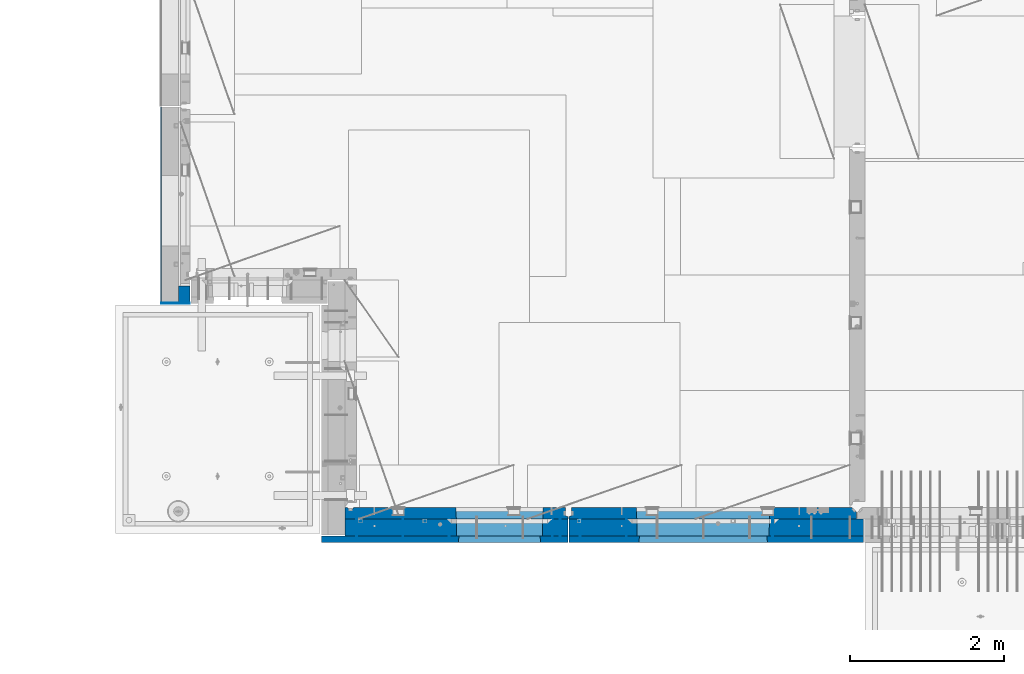
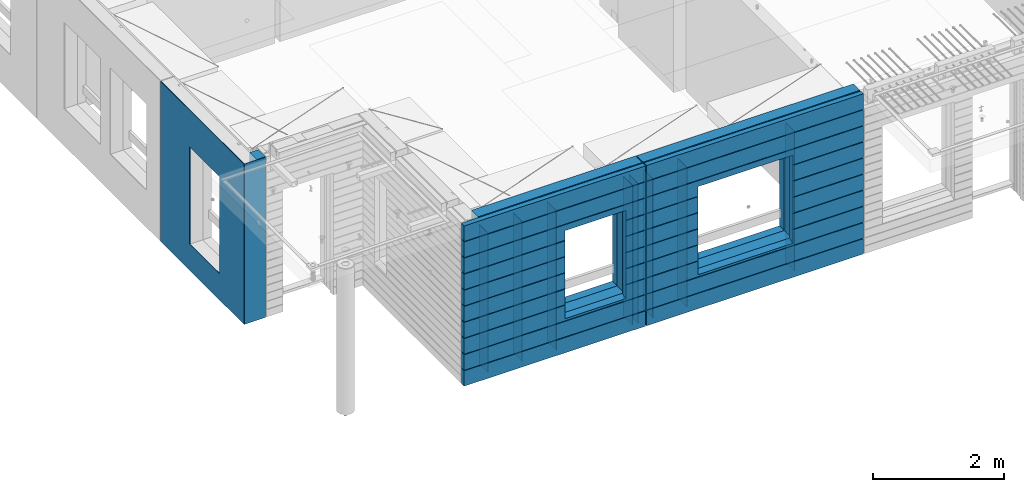
# One storey, part 226 of 349: 17 walls, 3 elements without a shape of their own.
"""IFC2X3 building model written with IfcOpenShell, lengths in millimetres."""

from ifc_helpers import new_model, si_unit, frame, origin_with_axes, place, context, subcontext, project, spatial, faceted_brep, material, type_object, element, aggregate, save


model = new_model("IFC2X3")

# Units and contexts
model_context = context("Model", 3, precision=1e-05, world=origin_with_axes())
body_context = subcontext(model_context, "Body", "Model", "MODEL_VIEW")
ifc_project = project(units=[si_unit("LENGTHUNIT", "METRE", prefix="MILLI"), si_unit("AREAUNIT", "SQUARE_METRE"), si_unit("VOLUMEUNIT", "CUBIC_METRE"), si_unit("MASSUNIT", "GRAM", prefix="KILO"), si_unit("TIMEUNIT", "SECOND"), si_unit("PLANEANGLEUNIT", "RADIAN"), si_unit("SOLIDANGLEUNIT", "STERADIAN"), si_unit("THERMODYNAMICTEMPERATUREUNIT", "DEGREE_CELSIUS"), si_unit("LUMINOUSINTENSITYUNIT", "LUMEN")], contexts=[model_context])

# Site, building, storey
site_placement = place(None, origin_with_axes())
site = spatial("IfcSite", under=ifc_project, at=site_placement, CompositionType="ELEMENT")
building_placement = place(site_placement, origin_with_axes())
building = spatial("IfcBuilding", under=site, at=building_placement, CompositionType="ELEMENT")
storey_placement = place(building_placement, origin_with_axes())
storey = spatial("IfcBuildingStorey", under=building, at=storey_placement, Name="4", CompositionType="ELEMENT", Elevation=0.0)

# Assembly, walls
assembly_1_placement = place(storey_placement, origin_with_axes())
assembly_1 = element("IfcElementAssembly", 1, at=assembly_1_placement, inside=storey, AssemblyPlace="NOTDEFINED", PredefinedType="REINFORCEMENT_UNIT")
ifc_material_1 = material(Name="Undefined")
wall_type_1 = type_object("IfcWallType", PredefinedType="NOTDEFINED")
wall_1_placement = place(assembly_1_placement, frame((10165.0, 7880.0, 92115.0), z_axis=(0.0, 0.0, 1.0), x_axis=(0.0, -1.0, 0.0)))
wall_1 = element("IfcWall", 2, at=wall_1_placement, type_object=wall_type_1, material=ifc_material_1, Name="(PD)", context=body_context, shape_type="Brep", body=[
    faceted_brep([(0.0, 5.0, -1300.0), (0.0, 5.0, 1300.0), (280.0, 5.0, 1300.0), (280.0, 5.0, -1300.0), (0.0, -5.0, 1300.0), (280.0, -5.0, 1300.0), (0.0, -5.0, -1300.0), (280.0, -5.0, -1300.0)], [[[0, 1, 2, 3]], [[1, 4, 5, 2]], [[4, 6, 7, 5]], [[6, 0, 3, 7]], [[5, 7, 3, 2]], [[6, 4, 1, 0]]]),
])
wall_2_placement = place(assembly_1_placement, frame((10765.0, 7880.0, 92115.0), z_axis=(0.0, 0.0, 1.0), x_axis=(0.0, -1.0, 0.0)))
wall_2 = element("IfcWall", 3, at=wall_2_placement, type_object=wall_type_1, material=ifc_material_1, Name="(PD)", context=body_context, shape_type="Brep", body=[
    faceted_brep([(0.0, 5.0, -1300.0), (0.0, 5.0, 1300.0), (280.0, 5.0, 1300.0), (280.0, 5.0, -1300.0), (0.0, -5.0, 1300.0), (280.0, -5.0, 1300.0), (0.0, -5.0, -1300.0), (280.0, -5.0, -1300.0)], [[[0, 1, 2, 3]], [[1, 4, 5, 2]], [[4, 6, 7, 5]], [[6, 0, 3, 7]], [[5, 7, 3, 2]], [[6, 4, 1, 0]]]),
])
wall_3_placement = place(assembly_1_placement, frame((12705.0, 7880.0, 92115.0), z_axis=(0.0, 0.0, 1.0), x_axis=(0.0, -1.0, 0.0)))
wall_3 = element("IfcWall", 4, at=wall_3_placement, type_object=wall_type_1, material=ifc_material_1, Name="(PD)", context=body_context, shape_type="Brep", body=[
    faceted_brep([(0.0, 5.0, -1300.0), (0.0, 5.0, 1300.0), (280.0, 5.0, 1300.0), (280.0, 5.0, -1300.0), (0.0, -5.0, 1300.0), (280.0, -5.0, 1300.0), (0.0, -5.0, -1300.0), (280.0, -5.0, -1300.0)], [[[0, 1, 2, 3]], [[1, 4, 5, 2]], [[4, 6, 7, 5]], [[6, 0, 3, 7]], [[5, 7, 3, 2]], [[6, 4, 1, 0]]]),
])
wall_4_placement = place(assembly_1_placement, frame((12805.0, 7880.0, 92115.0), z_axis=(0.0, 0.0, 1.0), x_axis=(0.0, -1.0, 0.0)))
wall_4 = element("IfcWall", 5, at=wall_4_placement, type_object=wall_type_1, material=ifc_material_1, Name="(PD)", context=body_context, shape_type="Brep", body=[
    faceted_brep([(0.0, 5.0, -1300.0), (0.0, 5.0, 1300.0), (280.0, 5.0, 1300.0), (280.0, 5.0, -1300.0), (0.0, -5.0, 1300.0), (280.0, -5.0, 1300.0), (0.0, -5.0, -1300.0), (280.0, -5.0, -1300.0)], [[[0, 1, 2, 3]], [[1, 4, 5, 2]], [[4, 6, 7, 5]], [[6, 0, 3, 7]], [[5, 7, 3, 2]], [[6, 4, 1, 0]]]),
])
wall_5_placement = place(assembly_1_placement, frame((11365.0, 7880.0, 92115.0), z_axis=(0.0, 0.0, 1.0), x_axis=(0.0, -1.0, 0.0)))
wall_5 = element("IfcWall", 6, at=wall_5_placement, type_object=wall_type_1, material=ifc_material_1, Name="(PD)", context=body_context, shape_type="Brep", body=[
    faceted_brep([(0.0, 5.0, -1300.0), (0.0, 5.0, 1300.0), (280.0, 5.0, 1300.0), (280.0, 5.0, -1300.0), (0.0, -5.0, 1300.0), (280.0, -5.0, 1300.0), (0.0, -5.0, -1300.0), (280.0, -5.0, -1300.0)], [[[0, 1, 2, 3]], [[1, 4, 5, 2]], [[4, 6, 7, 5]], [[6, 0, 3, 7]], [[5, 7, 3, 2]], [[6, 4, 1, 0]]]),
])

assembly_2_placement = place(storey_placement, origin_with_axes())
assembly_2 = element("IfcElementAssembly", 7, at=assembly_2_placement, inside=storey, AssemblyPlace="NOTDEFINED", PredefinedType="REINFORCEMENT_UNIT")
wall_6_placement = place(assembly_2_placement, frame((13665.0, 7880.0, 92115.0), z_axis=(0.0, 0.0, 1.0), x_axis=(0.0, -1.0, 0.0)))
wall_6 = element("IfcWall", 8, at=wall_6_placement, type_object=wall_type_1, material=ifc_material_1, Name="(PD)", context=body_context, shape_type="Brep", body=[
    faceted_brep([(0.0, 5.0, -1300.0), (0.0, 5.0, 1300.0), (280.0, 5.0, 1300.0), (280.0, 5.0, -1300.0), (0.0, -5.0, 1300.0), (280.0, -5.0, 1300.0), (0.0, -5.0, -1300.0), (280.0, -5.0, -1300.0)], [[[0, 1, 2, 3]], [[1, 4, 5, 2]], [[4, 6, 7, 5]], [[6, 0, 3, 7]], [[5, 7, 3, 2]], [[6, 4, 1, 0]]]),
])
wall_7_placement = place(assembly_2_placement, frame((13065.0, 7880.0, 92115.0), z_axis=(0.0, 0.0, 1.0), x_axis=(0.0, -1.0, 0.0)))
wall_7 = element("IfcWall", 9, at=wall_7_placement, type_object=wall_type_1, material=ifc_material_1, Name="(PD)", context=body_context, shape_type="Brep", body=[
    faceted_brep([(0.0, 5.0, -1300.0), (0.0, 5.0, 1300.0), (280.0, 5.0, 1300.0), (280.0, 5.0, -1300.0), (0.0, -5.0, 1300.0), (280.0, -5.0, 1300.0), (0.0, -5.0, -1300.0), (280.0, -5.0, -1300.0)], [[[0, 1, 2, 3]], [[1, 4, 5, 2]], [[4, 6, 7, 5]], [[6, 0, 3, 7]], [[5, 7, 3, 2]], [[6, 4, 1, 0]]]),
])
wall_8_placement = place(assembly_2_placement, frame((15565.0, 7880.0, 92115.0), z_axis=(0.0, 0.0, 1.0), x_axis=(0.0, -1.0, 0.0)))
wall_8 = element("IfcWall", 10, at=wall_8_placement, type_object=wall_type_1, material=ifc_material_1, Name="(PD)", context=body_context, shape_type="Brep", body=[
    faceted_brep([(0.0, 5.0, -1300.0), (0.0, 5.0, 1300.0), (280.0, 5.0, 1300.0), (280.0, 5.0, -1300.0), (0.0, -5.0, 1300.0), (280.0, -5.0, 1300.0), (0.0, -5.0, -1300.0), (280.0, -5.0, -1300.0)], [[[0, 1, 2, 3]], [[1, 4, 5, 2]], [[4, 6, 7, 5]], [[6, 0, 3, 7]], [[5, 7, 3, 2]], [[6, 4, 1, 0]]]),
])

# Assembly, wall
assembly_3_placement = place(storey_placement, origin_with_axes())
assembly_3 = element("IfcElementAssembly", 11, at=assembly_3_placement, inside=storey, AssemblyPlace="NOTDEFINED", PredefinedType="REINFORCEMENT_UNIT")
ifc_material_2 = material()
wall_type_2 = type_object("IfcWallType", PredefinedType="NOTDEFINED")
wall_9_placement = place(assembly_3_placement, frame((8000.00051558999, 10765.0000158944, 92247.5), z_axis=(0.0, 0.0, 1.0), x_axis=(-0.999999999997437, -2.26400000064461e-06, 0.0)))
wall_9 = element("IfcWall", 12, at=wall_9_placement, type_object=wall_type_2, material=ifc_material_2, context=body_context, shape_type="Brep", body=[
    faceted_brep([(0.0, 110.0, -1492.5), (0.0, 110.0, 1492.5), (150.000694320282, 109.999999999998, 1492.5), (150.000694320282, 109.999999999998, -1492.5), (0.0, -110.0, 1492.5), (150.000694320282, -110.000000000004, 1492.5), (0.0, -110.0, -1492.5), (150.000694320282, -110.000000000004, -1492.5)], [[[0, 1, 2, 3]], [[1, 4, 5, 2]], [[4, 6, 7, 5]], [[6, 0, 3, 7]], [[5, 7, 3, 2]], [[6, 4, 1, 0]]]),
])

# Wall
ifc_material_3 = material(Name="COS5gt")
wall_10_placement = place(assembly_1_placement, frame((12912.5, 7740.0, 92247.5), z_axis=(0.0, 0.0, 1.0), x_axis=(-1.0, 3.00000001838171e-08, 0.0)))
wall_10 = element("IfcWall", 13, at=wall_10_placement, type_object=wall_type_2, material=ifc_material_3, context=body_context, shape_type="Brep", body=[
    faceted_brep([(7.5, 90.0, 1442.5), (2897.5, 90.0, 1442.5), (2897.5, 110.0, 1442.5), (7.5, 110.0, 1442.5), (7.5, 90.0, 1492.5), (2897.5, 90.0, 1492.5), (7.5, -110.0, 1492.5), (2897.5, -110.0, 1492.5), (2897.5, -110.0, -1492.5), (2897.5, 90.0, -1492.5), (2897.5, 90.0, -1442.5), (2897.5, 110.0, -1442.5), (7.5, 110.0, -1442.5), (7.5, 90.0, -1442.5), (339.499571152144, 110.0, -807.5), (369.499571152144, 110.0, -807.5), (1419.49957115214, 110.0, -807.5), (1449.49957115214, 110.0, -807.5), (1449.49957115214, 110.0, -802.5), (1449.49957115214, 110.0, 807.5), (339.499571152144, 110.0, 807.5), (339.499571152144, 110.0, -802.5), (333.553625206197, -110.0, -813.445945945947), (333.553625206197, -110.0, 813.445945945947), (1455.44551709809, -110.0, -813.445945945947), (1455.44551709809, -110.0, 813.445945945947), (7.5, -110.0, -1492.5), (7.5, 90.0, -1492.5)], [[[0, 1, 2, 3]], [[4, 5, 1, 0]], [[6, 7, 5, 4]], [[2, 1, 5, 7, 8, 9, 10, 11]], [[12, 11, 10, 13]], [[3, 2, 11, 12], [14, 15, 16, 17, 18, 19, 20, 21]], [[22, 14, 21, 20, 23]], [[24, 17, 16, 15, 14, 22]], [[18, 17, 24, 25, 19]], [[23, 20, 19, 25]], [[6, 26, 8, 7], [24, 22, 23, 25]], [[8, 26, 27, 9]], [[13, 10, 9, 27]], [[26, 6, 4, 0, 3, 12, 13, 27]]]),
])

wall_11_placement = place(assembly_2_placement, frame((16740.0, 7740.0, 92247.5), z_axis=(0.0, 0.0, 1.0), x_axis=(-1.0, 3.00000001838171e-08, 0.0)))
wall_11 = element("IfcWall", 14, at=wall_11_placement, type_object=wall_type_2, material=ifc_material_3, context=body_context, shape_type="Brep", body=[
    faceted_brep([(0.0, 90.0, 1442.5), (3820.0, 90.0, 1442.5), (3820.0, 110.0, 1442.5), (0.0, 110.0, 1442.5), (0.0, 90.0, 1492.5), (3820.0, 90.0, 1492.5), (0.0, -110.0, 1492.5), (3820.0, -110.0, 1492.5), (3820.0, -110.0, -1492.5), (3820.0, 90.0, -1492.5), (3820.0, 90.0, -1442.5), (3820.0, 110.0, -1442.5), (0.0, 110.0, -1442.5), (0.0, 90.0, -1442.5), (1224.99975425761, 110.0, -807.5), (1254.99975425761, 110.0, -807.5), (2904.99975425761, 110.0, -807.5), (2934.99975425761, 110.0, -807.5), (2934.99975425761, 110.0, -802.5), (2934.99975425761, 110.0, 807.5), (1224.99975425761, 110.0, 807.5), (1224.99975425761, 110.0, -802.5), (1219.05380831167, -110.0, -813.445945945947), (1219.05380831167, -110.0, 813.445945945947), (2940.94570020356, -110.0, -813.445945945947), (2940.94570020356, -110.0, 813.445945945947), (0.0, -110.0, -1492.5), (0.0, 90.0, -1492.5)], [[[0, 1, 2, 3]], [[4, 5, 1, 0]], [[6, 7, 5, 4]], [[2, 1, 5, 7, 8, 9, 10, 11]], [[12, 11, 10, 13]], [[3, 2, 11, 12], [14, 15, 16, 17, 18, 19, 20, 21]], [[22, 14, 21, 20, 23]], [[24, 17, 16, 15, 14, 22]], [[18, 17, 24, 25, 19]], [[23, 20, 19, 25]], [[6, 26, 8, 7], [24, 22, 23, 25]], [[8, 26, 27, 9]], [[13, 10, 9, 27]], [[27, 26, 6, 4, 0, 3, 12, 13]]]),
])

ifc_material_4 = material(Name="CONCRETE/C30/37")
wall_type_3 = type_object("IfcWallType", PredefinedType="NOTDEFINED")
wall_12_placement = place(assembly_1_placement, frame((12912.5, 7587.5, 92247.5), z_axis=(0.0, 0.0, 1.0), x_axis=(-1.0, 3.00000001838171e-08, 0.0)))
wall_12 = element("IfcWall", 15, at=wall_12_placement, type_object=wall_type_3, material=ifc_material_4, context=body_context, shape_type="Brep", body=[
    faceted_brep([(3207.5, -42.5, 1193.0000011433), (3207.5, 42.5, 1192.99999994476), (3197.49999925687, 32.4999992501671, 1194.99999999921), (3197.49999396174, -42.5, 1195.00000105656), (3197.49999368253, -42.5, 1205.00000145777), (3197.49999897767, 32.4999991121604, 1205.00000040043), (3207.5, 42.5, 1206.99999988925), (3207.5, -42.5, 1207.0000010878), (7.4999999999709, -42.5, -1492.5), (7.4999999999709, 42.5, -1492.5), (3207.5, 42.5, -1492.5), (3207.5, -42.5, -1492.5), (7.4999999999709, 42.5, -1207.00000005524), (3207.5, 42.5, -1207.00000005524), (3207.5, -42.5, -1206.9999988567), (3197.49999925687, 32.4999992501671, -1205.00000000079), (3197.49999396174, -42.5, -1204.99999894344), (7.4999999999709, 32.4999992501671, -1205.00000000079), (7.4999999999709, 32.4999991121604, -1194.99999959957), (3197.49999897767, 32.4999991121604, -1194.99999959957), (3197.49999368253, -42.5, -1194.99999854223), (3207.5, -42.5, -1192.9999989122), (3207.5, 42.5, -1193.00000011075), (3207.5, 42.5, -907.000000055239), (3207.5, -42.5, -906.9999988567), (7.4999999999709, 42.5, -1193.00000011075), (7.4999999999709, 42.5, -907.000000055239), (7.4999999999709, 32.4999992501671, -905.000000000786), (3197.49999925687, 32.4999992501671, -905.000000000786), (3197.49999396174, -42.5, -904.999998943444), (3197.49999897767, 32.4999991121604, -894.999999599575), (3197.49999368253, -42.5, -894.999998542233), (7.4999999999709, 32.4999991121604, -894.999999599575), (7.4999999999709, 42.5, -893.000000110755), (3207.5, 42.5, -893.000000110755), (3207.5, -42.5, -892.999998912201), (3207.5, 42.5, -607.000000055239), (3207.5, -42.5, -606.9999988567), (3197.49999925687, 32.4999992501671, -605.000000000786), (3197.49999396174, -42.5, -604.999998943444), (1429.49957115214, 42.5, -607.000000055239), (1428.32310047569, 32.4999992501653, -605.000000000786), (1428.32310045946, 32.4999991121585, -594.999999599575), (3197.49999897767, 32.4999991121604, -594.999999599575), (3197.49999368253, -42.5, -594.999998542233), (3207.5, 42.5, -593.000000110755), (3207.5, -42.5, -592.999998912201), (1429.49957115214, 42.5, -593.000000110755), (3207.5, 42.5, -307.000000055239), (1429.49957115214, 42.5, -307.000000055239), (3207.5, -42.5, -306.9999988567), (3197.49999925687, 32.4999992501671, -305.000000000786), (3197.49999396174, -42.5, -304.999998943444), (1428.32310047569, 32.4999992501653, -305.000000000786), (1428.32310045946, 32.4999991121585, -294.999999599575), (3197.49999897767, 32.4999991121604, -294.999999599575), (3197.49999368253, -42.5, -294.999998542233), (3207.5, 42.5, -293.000000110755), (3207.5, -42.5, -292.999998912201), (1429.49957115214, 42.5, -293.000000110755), (3207.5, 42.5, -7.00000005523907), (1429.49957115214, 42.5, -7.00000005523907), (3207.5, -42.5, -6.99999885669968), (3197.49999925687, 32.4999992501671, -5.0000000007858), (3197.49999396174, -42.5, -4.99999894344364), (1428.32310047569, 32.4999992501653, -5.0000000007858), (1428.32310045946, 32.4999991121585, 5.00000040042505), (3197.49999897767, 32.4999991121604, 5.00000040042505), (3197.49999368253, -42.5, 5.00000145776721), (3207.5, 42.5, 6.99999988924537), (3207.5, -42.5, 7.00000108779932), (1429.49957115214, 42.5, 6.99999988924537), (3207.5, 42.5, 292.999999944761), (1429.49957115214, 42.5, 292.999999944761), (3207.5, -42.5, 293.0000011433), (3197.49999925687, 32.4999992501671, 294.999999999214), (3197.49999396174, -42.5, 295.000001056556), (1428.32310047569, 32.4999992501653, 294.999999999214), (1428.32310045946, 32.4999991121585, 305.000000400425), (3197.49999897767, 32.4999991121604, 305.000000400425), (3197.49999368253, -42.5, 305.000001457767), (3207.5, -42.5, 307.000001087799), (3207.5, 42.5, 306.999999889245), (3207.5, 42.5, 592.999999944761), (3207.5, -42.5, 593.0000011433), (1429.49957115214, 42.5, 306.999999889245), (1429.49957115214, 42.5, 592.999999944761), (1428.32310047569, 32.4999992501653, 594.999999999214), (3197.49999925687, 32.4999992501671, 594.999999999214), (3197.49999396174, -42.5, 595.000001056556), (3197.49999897767, 32.4999991121604, 605.000000400425), (3197.49999368253, -42.5, 605.000001457767), (1428.32310045946, 32.4999991121585, 605.000000400425), (1429.49957115214, 42.5, 606.999999889245), (3207.5, 42.5, 606.999999889245), (3207.5, -42.5, 607.000001087799), (3207.5, 42.5, 892.999999944761), (3207.5, -42.5, 893.0000011433), (3197.49999925687, 32.4999992501671, 894.999999999214), (3197.49999396174, -42.5, 895.000001056556), (7.4999999999709, 42.5, 892.999999944761), (7.49999999998181, 32.4999992501671, 894.999999999214), (7.49999999998181, 32.4999991121604, 905.000000400425), (3197.49999897767, 32.4999991121604, 905.000000400425), (3197.49999368253, -42.5, 905.000001457767), (3207.5, -42.5, 907.000001087799), (3207.5, 42.5, 906.999999889245), (7.4999999999709, 42.5, 906.999999889245), (7.4999999999709, 42.5, 1192.99999994476), (7.49999999998363, 32.4999992501671, 1194.99999999921), (7.4999999999709, 42.5, 1492.5), (7.4999999999709, -42.5, 1492.5), (3207.5, -42.5, 1492.5), (3207.5, 42.5, 1492.5), (7.4999999999709, 42.5, 1206.99999988925), (7.49999999998363, 32.4999991121604, 1205.00000040043), (7.4999999999709, 42.5, 606.999999889245), (7.49999999997999, 32.4999991121604, 605.000000400425), (7.49999999997999, 32.4999992501671, 594.999999999214), (7.4999999999709, 42.5, 592.999999944761), (7.4999999999709, 42.5, 306.999999889245), (7.49999999997453, 32.4999991121604, 305.000000400425), (7.49999999997453, 32.4999992501671, 294.999999999214), (7.4999999999709, 42.5, 292.999999944761), (7.4999999999709, 42.5, 6.99999988924537), (7.4999999999709, 32.4999991121604, 5.00000040042505), (7.4999999999709, 32.4999992501671, -5.0000000007858), (7.4999999999709, 42.5, -7.00000005523907), (7.4999999999709, 42.5, -293.000000110755), (7.4999999999709, 32.4999991121604, -294.999999599575), (7.4999999999709, 32.4999992501671, -305.000000000786), (7.4999999999709, 42.5, -307.000000055239), (7.4999999999709, 42.5, -593.000000110755), (7.49999999996908, 32.4999991121604, -594.999999599575), (7.49999999996908, 32.4999992501671, -605.000000000786), (7.4999999999709, 42.5, -607.000000055239), (360.676041844832, 32.4999991121585, 605.000000400425), (360.676041828596, 32.4999992501653, 594.999999999214), (359.499571152144, 42.5, 592.999999944761), (359.499571152144, 42.5, 306.999999889245), (360.676041844832, 32.4999991121585, 305.000000400425), (360.676041828596, 32.4999992501653, 294.999999999214), (359.499571152144, 42.5, 292.999999944761), (359.499571152144, 42.5, 6.99999988924537), (360.676041844832, 32.4999991121585, 5.00000040042505), (360.676041828596, 32.4999992501653, -5.0000000007858), (359.499571152144, 42.5, -7.00000005523907), (359.499571152144, 42.5, -293.000000110755), (360.676041844832, 32.4999991121585, -294.999999599575), (360.676041828596, 32.4999992501653, -305.000000000786), (359.499571152144, 42.5, -307.000000055239), (359.499571152144, 42.5, -593.000000110755), (360.676041844832, 32.4999991121585, -594.999999599575), (360.676041828596, 32.4999992501653, -605.000000000786), (359.499571152144, 42.5, -607.000000055239), (1429.49957115214, 42.5, -857.5), (359.499571152144, 42.5, -857.5), (369.499571152144, -42.5, -807.5), (1419.49957115214, -42.5, -807.5), (1419.49957115214, -42.5, 782.5), (1419.49957115214, -42.5, 787.5), (1429.49957115214, 42.5, 782.5), (1419.49957115214, 42.5, 782.5), (369.499571152144, 42.5, 782.5), (359.499571152144, 42.5, 782.5), (359.499571152144, 42.5, 606.999999889245), (369.499571152144, -42.5, 787.5), (369.499571152144, -42.5, 782.5)], [[[0, 1, 2, 3]], [[4, 5, 6, 7]], [[3, 2, 5, 4]], [[8, 9, 10, 11]], [[10, 9, 12, 13]], [[11, 10, 13, 14]], [[14, 13, 15, 16]], [[12, 17, 15, 13]], [[17, 18, 19, 15]], [[16, 15, 19, 20]], [[21, 22, 23, 24]], [[20, 19, 22, 21]], [[18, 25, 22, 19]], [[22, 25, 26, 23]], [[26, 27, 28, 23]], [[24, 23, 28, 29]], [[29, 28, 30, 31]], [[27, 32, 30, 28]], [[32, 33, 34, 30]], [[31, 30, 34, 35]], [[35, 34, 36, 37]], [[37, 36, 38, 39]], [[40, 41, 38, 36]], [[41, 42, 43, 38]], [[39, 38, 43, 44]], [[44, 43, 45, 46]], [[42, 47, 45, 43]], [[48, 45, 47, 49]], [[46, 45, 48, 50]], [[50, 48, 51, 52]], [[49, 53, 51, 48]], [[53, 54, 55, 51]], [[52, 51, 55, 56]], [[56, 55, 57, 58]], [[54, 59, 57, 55]], [[60, 57, 59, 61]], [[58, 57, 60, 62]], [[62, 60, 63, 64]], [[61, 65, 63, 60]], [[65, 66, 67, 63]], [[64, 63, 67, 68]], [[68, 67, 69, 70]], [[66, 71, 69, 67]], [[72, 69, 71, 73]], [[70, 69, 72, 74]], [[74, 72, 75, 76]], [[73, 77, 75, 72]], [[77, 78, 79, 75]], [[76, 75, 79, 80]], [[81, 82, 83, 84]], [[80, 79, 82, 81]], [[78, 85, 82, 79]], [[83, 82, 85, 86]], [[86, 87, 88, 83]], [[84, 83, 88, 89]], [[89, 88, 90, 91]], [[87, 92, 90, 88]], [[92, 93, 94, 90]], [[91, 90, 94, 95]], [[95, 94, 96, 97]], [[97, 96, 98, 99]], [[100, 101, 98, 96]], [[101, 102, 103, 98]], [[99, 98, 103, 104]], [[105, 106, 1, 0]], [[104, 103, 106, 105]], [[102, 107, 106, 103]], [[106, 107, 108, 1]], [[108, 109, 2, 1]], [[110, 111, 112, 113]], [[113, 112, 7, 6]], [[110, 113, 6, 114]], [[115, 114, 6, 5]], [[109, 115, 5, 2]], [[108, 107, 102, 101, 100, 116, 117, 118, 119, 120, 121, 122, 123, 124, 125, 126, 127, 128, 129, 130, 131, 132, 133, 134, 135, 33, 32, 27, 26, 25, 18, 17, 12, 9, 8, 111, 110, 114, 115, 109]], [[118, 117, 136, 137]], [[119, 118, 137, 138]], [[120, 119, 138, 139]], [[121, 120, 139, 140]], [[122, 121, 140, 141]], [[123, 122, 141, 142]], [[124, 123, 142, 143]], [[125, 124, 143, 144]], [[126, 125, 144, 145]], [[127, 126, 145, 146]], [[128, 127, 146, 147]], [[129, 128, 147, 148]], [[130, 129, 148, 149]], [[131, 130, 149, 150]], [[132, 131, 150, 151]], [[133, 132, 151, 152]], [[134, 133, 152, 153]], [[135, 134, 153, 154]], [[155, 40, 36, 34, 33, 135, 154, 156]], [[156, 157, 158, 155]], [[159, 160, 161, 93, 92, 87, 86, 85, 78, 77, 73, 71, 66, 65, 61, 59, 54, 53, 49, 47, 42, 41, 40, 155, 158]], [[116, 100, 96, 94, 93, 161, 162, 163, 164, 165]], [[117, 116, 165, 136]], [[164, 166, 167, 157, 156, 154, 153, 152, 151, 150, 149, 148, 147, 146, 145, 144, 143, 142, 141, 140, 139, 138, 137, 136, 165]], [[163, 162, 161, 160, 166, 164]], [[112, 111, 8, 11, 14, 16, 20, 21, 24, 29, 31, 35, 37, 39, 44, 46, 50, 52, 56, 58, 62, 64, 68, 70, 74, 76, 80, 81, 84, 89, 91, 95, 97, 99, 104, 105, 0, 3, 4, 7], [159, 158, 157, 167, 166, 160]]]),
])

wall_13_placement = place(assembly_2_placement, frame((16740.0, 7587.5, 92247.5), z_axis=(0.0, 0.0, 1.0), x_axis=(-1.0, 3.00000001838171e-08, 0.0)))
wall_13 = element("IfcWall", 16, at=wall_13_placement, type_object=wall_type_3, material=ifc_material_4, context=body_context, shape_type="Brep", body=[
    faceted_brep([(3820.00000000003, 42.5, 606.999999889245), (3820.00000000002, 32.4999991121731, 605.00000040044), (2913.82328356493, 32.4999991121731, 605.00000040044), (2914.99975425761, 42.5, 606.999999889245), (3820.00000000002, 32.4999992501716, 594.999999999243), (2913.82328358116, 32.4999992501716, 594.999999999243), (3820.00000000003, 42.5, 592.999999944761), (2914.99975425761, 42.5, 592.999999944761), (3820.00000000003, 42.5, 306.999999889245), (2914.99975425761, 42.5, 306.999999889245), (3820.00000000002, 32.4999991121731, 305.00000040044), (2913.82328356493, 32.4999991121731, 305.00000040044), (3820.00000000002, 32.4999992501716, 294.999999999243), (2913.82328358116, 32.4999992501716, 294.999999999243), (3820.00000000003, 42.5, 292.999999944761), (2914.99975425761, 42.5, 292.999999944761), (3820.00000000003, 42.5, 6.99999988924537), (2914.99975425761, 42.5, 6.99999988924537), (3820.00000000003, 32.4999991121731, 5.0000004004396), (2913.82328356493, 32.4999991121731, 5.0000004004396), (3820.00000000003, 32.4999992501716, -5.0000000007567), (2913.82328358116, 32.4999992501716, -5.0000000007567), (3820.00000000003, 42.5, -7.00000005523907), (2914.99975425761, 42.5, -7.00000005523907), (3820.00000000003, 42.5, -293.000000110755), (2914.99975425761, 42.5, -293.000000110755), (3820.00000000003, 32.4999991121731, -294.99999959956), (2913.82328356493, 32.4999991121731, -294.99999959956), (3820.00000000003, 32.4999992501716, -305.000000000757), (2913.82328358116, 32.4999992501716, -305.000000000757), (3820.00000000003, 42.5, -307.000000055239), (2914.99975425761, 42.5, -307.000000055239), (3820.00000000003, 42.5, -593.000000110755), (2914.99975425761, 42.5, -593.000000110755), (3820.00000000003, 32.4999991121731, -594.99999959956), (2913.82328356493, 32.4999991121731, -594.99999959956), (3820.00000000003, 32.4999992501716, -605.000000000757), (2913.82328358116, 32.4999992501716, -605.000000000757), (3820.00000000003, 42.5, -607.000000055239), (2914.99975425761, 42.5, -607.000000055239), (0.0, -42.5, -1492.5), (0.0, 42.5, -1492.5), (3820.00000000003, 42.5, -1492.5), (3820.00000000003, -42.5, -1492.5), (0.0, 42.5, -1207.00000005524), (3820.00000000003, 42.5, -1207.00000005524), (0.0, 32.4999992507037, -1205.00000000074), (3820.00000000003, 32.4999992501716, -1205.00000000076), (0.0, 32.4999991127006, -1194.99999959956), (3820.00000000003, 32.4999991121731, -1194.99999959956), (0.0, 42.5, -1193.00000011075), (3820.00000000003, 42.5, -1193.00000011075), (0.0, 42.5, -907.000000055239), (3820.00000000003, 42.5, -907.000000055239), (0.0, 32.4999992507037, -905.000000000742), (3820.00000000003, 32.4999992501716, -905.000000000757), (0.0, 32.4999991127006, -894.99999959956), (3820.00000000003, 32.4999991121731, -894.99999959956), (0.0, 42.5, -893.000000110755), (3820.00000000003, 42.5, -893.000000110755), (3.63797880709171e-12, 32.4999992507037, 594.999999999258), (3.63797880709171e-12, 32.4999991127006, 605.00000040044), (1246.1762249503, 32.4999991121731, 605.00000040044), (1246.17622493406, 32.4999992501716, 594.999999999243), (0.0, 42.5, 592.999999944761), (1244.99975425761, 42.5, 592.999999944761), (0.0, 42.5, 306.999999889245), (1244.99975425761, 42.5, 306.999999889245), (-3.63797880709171e-12, 32.4999991127006, 305.00000040044), (1246.1762249503, 32.4999991121731, 305.00000040044), (-3.63797880709171e-12, 32.4999992507037, 294.999999999258), (1246.17622493406, 32.4999992501716, 294.999999999243), (0.0, 42.5, 292.999999944761), (1244.99975425761, 42.5, 292.999999944761), (0.0, 42.5, 6.99999988924537), (1244.99975425761, 42.5, 6.99999988924537), (0.0, 32.4999991127006, 5.0000004004396), (1246.1762249503, 32.4999991121731, 5.0000004004396), (0.0, 32.4999992507037, -5.00000000074215), (1246.17622493406, 32.4999992501716, -5.0000000007567), (0.0, 42.5, -7.00000005523907), (1244.99975425761, 42.5, -7.00000005523907), (0.0, 42.5, -293.000000110755), (1244.99975425761, 42.5, -293.000000110755), (0.0, 32.4999991127006, -294.99999959956), (1246.1762249503, 32.4999991121731, -294.99999959956), (0.0, 32.4999992507037, -305.000000000742), (1246.17622493406, 32.4999992501716, -305.000000000757), (0.0, 42.5, -307.000000055239), (1244.99975425761, 42.5, -307.000000055239), (0.0, 42.5, -593.000000110755), (1244.99975425761, 42.5, -593.000000110755), (3.63797880709171e-12, 32.4999991127006, -594.99999959956), (1246.1762249503, 32.4999991121731, -594.99999959956), (3.63797880709171e-12, 32.4999992507037, -605.000000000742), (1246.17622493406, 32.4999992501716, -605.000000000757), (0.0, 42.5, -607.000000055239), (1244.99975425761, 42.5, -607.000000055239), (2914.99975425761, 42.5, -857.5), (1244.99975425761, 42.5, -857.5), (1254.99975425761, -42.5, -807.5), (2904.99975425761, -42.5, -807.5), (2904.99975425761, -42.5, 782.5), (2904.99975425761, -42.5, 787.5), (2914.99975425761, 42.5, 782.5), (1254.99975425761, 42.5, 782.5), (2904.99975425761, 42.5, 782.5), (1254.99975425761, -42.5, 787.5), (1244.99975425761, 42.5, 782.5), (0.0, -42.5, 1492.5), (3820.00000000003, -42.5, 1492.5), (1254.99975425761, -42.5, 782.5), (0.0, 42.5, 1492.5), (3820.00000000003, 42.5, 1492.5), (3820.00000000003, 42.5, 1206.99999988925), (0.0, 42.5, 1206.99999988925), (3820.00000000002, 32.4999991121731, 1205.00000040044), (0.0, 32.4999991127006, 1205.00000040044), (3820.00000000003, 42.5, 892.999999944761), (3820.00000000002, 32.4999992501716, 894.999999999243), (3820.00000000002, 32.4999991121731, 905.00000040044), (3820.00000000003, 42.5, 906.999999889245), (3820.00000000003, 42.5, 1192.99999994476), (3820.00000000002, 32.4999992501716, 1194.99999999924), (0.0, 42.5, 906.999999889245), (0.0, 42.5, 1192.99999994476), (0.0, 32.4999992507037, 1194.99999999926), (0.0, 32.4999991127006, 905.00000040044), (0.0, 32.4999992507037, 894.999999999258), (0.0, 42.5, 892.999999944761), (0.0, 42.5, 606.999999889245), (1244.99975425761, 42.5, 606.999999889245)], [[[0, 1, 2, 3]], [[1, 4, 5, 2]], [[4, 6, 7, 5]], [[6, 8, 9, 7]], [[8, 10, 11, 9]], [[10, 12, 13, 11]], [[12, 14, 15, 13]], [[14, 16, 17, 15]], [[16, 18, 19, 17]], [[18, 20, 21, 19]], [[20, 22, 23, 21]], [[22, 24, 25, 23]], [[24, 26, 27, 25]], [[26, 28, 29, 27]], [[28, 30, 31, 29]], [[30, 32, 33, 31]], [[32, 34, 35, 33]], [[34, 36, 37, 35]], [[36, 38, 39, 37]], [[40, 41, 42, 43]], [[42, 41, 44, 45]], [[46, 47, 45, 44]], [[48, 49, 47, 46]], [[50, 51, 49, 48]], [[51, 50, 52, 53]], [[54, 55, 53, 52]], [[56, 57, 55, 54]], [[58, 59, 57, 56]], [[60, 61, 62, 63]], [[64, 60, 63, 65]], [[66, 64, 65, 67]], [[68, 66, 67, 69]], [[70, 68, 69, 71]], [[72, 70, 71, 73]], [[74, 72, 73, 75]], [[76, 74, 75, 77]], [[78, 76, 77, 79]], [[80, 78, 79, 81]], [[82, 80, 81, 83]], [[84, 82, 83, 85]], [[86, 84, 85, 87]], [[88, 86, 87, 89]], [[90, 88, 89, 91]], [[92, 90, 91, 93]], [[94, 92, 93, 95]], [[96, 94, 95, 97]], [[98, 39, 38, 59, 58, 96, 97, 99]], [[99, 100, 101, 98]], [[102, 103, 104, 3, 2, 5, 7, 9, 11, 13, 15, 17, 19, 21, 23, 25, 27, 29, 31, 33, 35, 37, 39, 98, 101]], [[105, 106, 104, 103, 107, 108]], [[109, 40, 43, 110], [102, 101, 100, 111, 107, 103]], [[112, 109, 110, 113]], [[112, 113, 114, 115]], [[115, 114, 116, 117]], [[113, 110, 43, 42, 45, 47, 49, 51, 53, 55, 57, 59, 38, 36, 34, 32, 30, 28, 26, 24, 22, 20, 18, 16, 14, 12, 10, 8, 6, 4, 1, 0, 118, 119, 120, 121, 122, 123, 116, 114]], [[121, 124, 125, 122]], [[126, 123, 122, 125]], [[117, 116, 123, 126]], [[125, 124, 127, 128, 129, 130, 61, 60, 64, 66, 68, 70, 72, 74, 76, 78, 80, 82, 84, 86, 88, 90, 92, 94, 96, 58, 56, 54, 52, 50, 48, 46, 44, 41, 40, 109, 112, 115, 117, 126]], [[61, 130, 131, 62]], [[108, 107, 111, 100, 99, 97, 95, 93, 91, 89, 87, 85, 83, 81, 79, 77, 75, 73, 71, 69, 67, 65, 63, 62, 131]], [[130, 129, 118, 0, 3, 104, 106, 105, 108, 131]], [[128, 119, 118, 129]], [[127, 120, 119, 128]], [[124, 121, 120, 127]]]),
])

ifc_material_5 = material(Name="CONCRETE/C25/30")
wall_type_4 = type_object("IfcWallType", PredefinedType="NOTDEFINED")
wall_14_placement = place(assembly_1_placement, frame((12912.5, 7925.0, 92112.5), z_axis=(0.0, 0.0, 1.0), x_axis=(-1.0, 3.00000001838171e-08, 0.0)))
wall_14 = element("IfcWall", 17, at=wall_14_placement, type_object=wall_type_4, material=ifc_material_5, context=body_context, shape_type="Brep", body=[
    faceted_brep([(2787.5, -75.0, 1357.5), (2787.5, -75.0, -1357.5), (2800.5, -55.0, -1357.5), (2800.5, -55.0, 1357.5), (2852.5, -55.0, 1357.5), (2802.5, -55.0, 1357.5), (2802.5, -55.0, -1357.5), (2852.5, -55.0, -1357.5), (2854.5, -55.0, -1357.5), (2854.5, -55.0, 1357.5), (2867.5, -75.0, -1357.5), (2867.5, -75.0, 1357.5), (2897.5, -75.0, -1357.5), (2897.5, -75.0, 1357.5), (2897.5, 75.0, -1357.5), (2897.5, 75.0, 1357.5), (40.0, -75.0, 1357.5), (7.4999999999709, 75.0, 1357.5), (7.5, 45.0, 1357.5), (40.0, 32.0, 1357.5), (7.4999999999709, 75.0, -1357.5), (7.4999999999709, 45.0, -1357.5), (40.0, 32.0, -1357.5), (40.0, -75.0, -1357.5), (1459.49957115214, -75.0, -682.5), (329.499571152144, -75.0, -682.5), (329.499571152144, -75.0, 952.5), (1459.49957115214, -75.0, 952.5), (1455.44551709809, 75.0, -678.445945945947), (333.553625206197, 75.0, -678.445945945947), (333.553625206197, 75.0, 948.445945945947), (1455.44551709809, 75.0, 948.445945945947)], [[[0, 1, 2, 3]], [[4, 5, 3, 2, 6, 7, 8, 9]], [[9, 8, 10, 11]], [[12, 13, 11, 10]], [[13, 12, 14, 15]], [[16, 0, 3, 5, 4, 9, 11, 13, 15, 17, 18, 19]], [[17, 20, 21, 18]], [[18, 21, 22, 19]], [[20, 14, 12, 10, 8, 7, 6, 2, 1, 23, 22, 21]], [[16, 19, 22, 23]], [[1, 0, 16, 23], [24, 25, 26, 27]], [[24, 28, 29, 25]], [[25, 29, 30, 26]], [[20, 17, 15, 14], [28, 31, 30, 29]], [[26, 30, 31, 27]], [[28, 24, 27, 31]]]),
])

aggregate(assembly_1, [wall_1, wall_2, wall_3, wall_4, wall_5, wall_12, wall_10, wall_14])

wall_15_placement = place(assembly_2_placement, frame((16660.0, 7925.0, 92112.5), z_axis=(0.0, 0.0, 1.0), x_axis=(-1.0, 3.00000001838171e-08, 0.0)))
wall_15 = element("IfcWall", 18, at=wall_15_placement, type_object=wall_type_4, material=ifc_material_5, context=body_context, shape_type="Brep", body=[
    faceted_brep([(10.0, 75.0, 1357.5), (10.0, 75.0, -1357.5), (10.0, -15.0, -1357.5), (10.0, -15.0, 1357.5), (70.0, -75.0, -1357.5), (3740.00000000003, 75.0, -1357.5), (3740.00000000003, 45.0, -1357.5), (3707.5, 32.0, -1357.5), (3707.5, -75.0, -1357.5), (70.0, -75.0, 1357.5), (3740.00000000003, 45.0, 1357.5), (3740.00000000003, 75.0, 1357.5), (3707.5, -75.0, 1357.5), (3707.5, 32.0, 1357.5), (2864.99975425761, -75.0, -682.5), (1134.99975425761, -75.0, -682.5), (1134.99975425761, -75.0, 952.5), (2864.99975425761, -75.0, 952.5), (2860.94570020356, 75.0, -678.445945945947), (1139.05380831167, 75.0, -678.445945945947), (1139.05380831167, 75.0, 948.445945945947), (2860.94570020356, 75.0, 948.445945945947)], [[[0, 1, 2, 3]], [[4, 2, 1, 5, 6, 7, 8]], [[3, 2, 4, 9]], [[10, 11, 0, 3, 9, 12, 13]], [[5, 11, 10, 6]], [[13, 7, 6, 10]], [[12, 8, 7, 13]], [[9, 4, 8, 12], [14, 15, 16, 17]], [[14, 18, 19, 15]], [[15, 19, 20, 16]], [[1, 0, 11, 5], [18, 21, 20, 19]], [[16, 20, 21, 17]], [[18, 14, 17, 21]]]),
])

aggregate(assembly_2, [wall_6, wall_7, wall_8, wall_13, wall_11, wall_15])

wall_type_5 = type_object("IfcWallType", PredefinedType="NOTDEFINED")
wall_16_placement = place(assembly_3_placement, frame((8000.00033490857, 10650.0000304601, 92247.5), z_axis=(0.0, 0.0, 1.0), x_axis=(-1.0, 3.00000001838171e-08, 0.0)))
wall_16 = element("IfcWall", 19, at=wall_16_placement, type_object=wall_type_5, material=ifc_material_4, context=body_context, shape_type="Brep", body=[
    faceted_brep([(0.0, 5.0, -1492.5), (0.0, 5.0, 1492.5), (370.000694320092, 4.99999999999818, 1492.5), (370.000694320092, 4.99999999999818, -1492.5), (0.0, -5.0, 1492.5), (370.000694320092, -5.0, 1492.5), (0.0, -5.0, -1492.5), (370.000694320092, -5.0, -1492.5)], [[[0, 1, 2, 3]], [[1, 4, 5, 2]], [[4, 6, 7, 5]], [[6, 0, 3, 7]], [[5, 7, 3, 2]], [[6, 4, 1, 0]]]),
])

wall_17_placement = place(assembly_3_placement, frame((7625.00002947765, 10874.99966857, 92247.5), z_axis=(0.0, 0.0, 1.0), x_axis=(0.0, 1.0, 0.0)))
wall_17 = element("IfcWall", 20, at=wall_17_placement, type_object=wall_type_5, material=ifc_material_4, context=body_context, shape_type="Brep", body=[
    faceted_brep([(-230.0, -5.0, 1492.5), (-230.0, -5.0, -1492.5), (2320.00069431993, -5.0, -1492.5), (2320.00069431993, -5.0, 1492.5), (520.000578774374, -5.0, -1002.5), (520.000578774374, -5.0, 807.5), (1430.00057877438, -5.0, 807.5), (1430.00057877438, -5.0, -1002.5), (-230.0, 5.0, 1492.5), (2320.00069431993, 5.0, 1492.5), (-230.0, 5.0, -1492.5), (2320.00069431993, 5.0, -1492.5), (520.000578774374, 5.0, -1002.5), (1430.00057877438, 5.0, -1002.5), (1430.00057877438, 5.0, 807.5), (520.000578774374, 5.0, 807.5)], [[[0, 1, 2, 3], [4, 5, 6, 7]], [[8, 0, 3, 9]], [[1, 0, 8, 10]], [[1, 10, 11, 2]], [[3, 2, 11, 9]], [[10, 8, 9, 11], [12, 13, 14, 15]], [[6, 14, 13, 7]], [[5, 15, 14, 6]], [[4, 12, 15, 5]], [[7, 13, 12, 4]]]),
])

aggregate(assembly_3, [wall_16, wall_9, wall_17])

save(model, "model.ifc")
